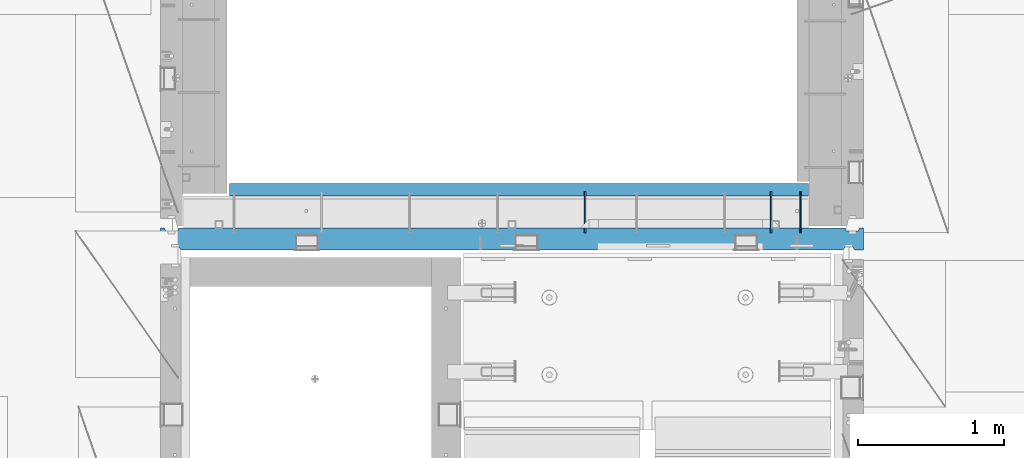
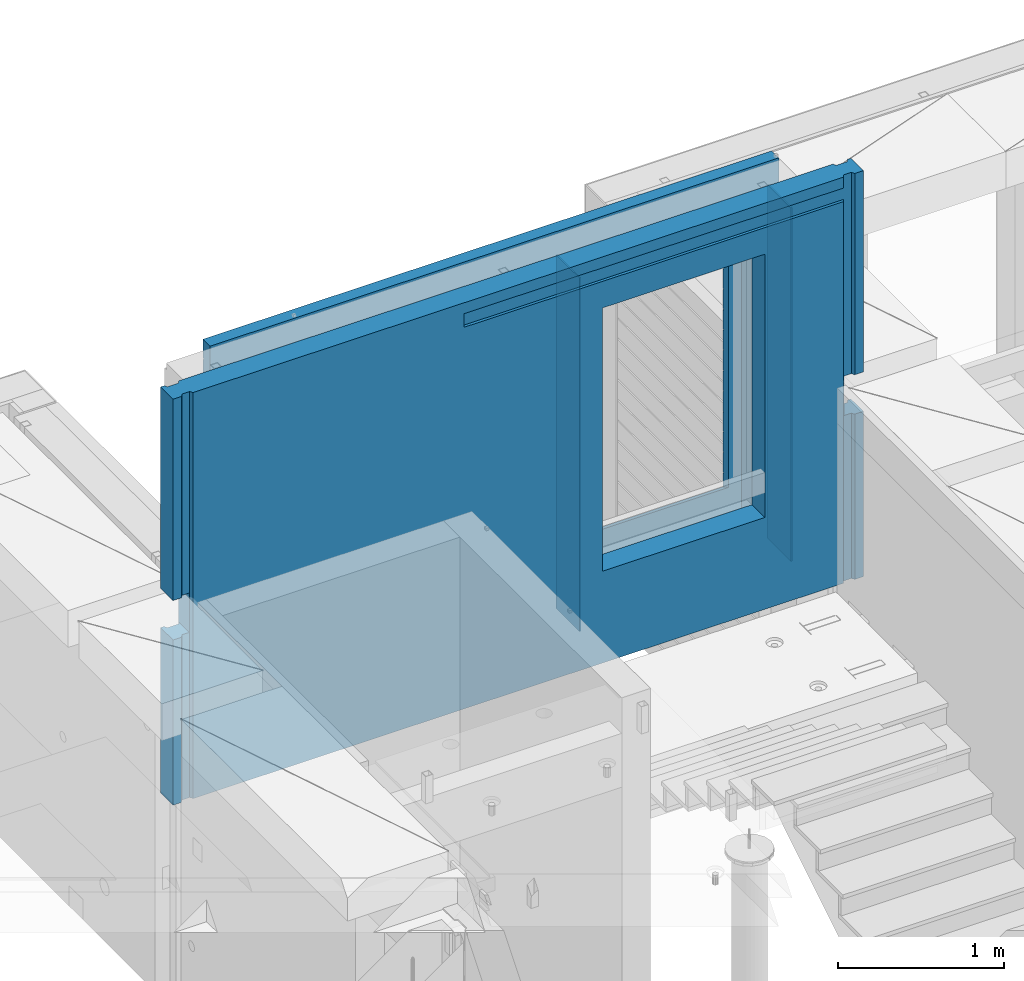
# One storey, part 230 of 341: 5 walls, 1 element without a shape of its own.
"""IFC2X3 building model written with IfcOpenShell, lengths in millimetres."""

import ifcopenshell
import ifcopenshell.guid

model = None  # the IFC model being written
_history = None  # IfcOwnerHistory: only IFC2X3 demands one
_inside = {}  # id of a spatial element -> (the spatial element, [elements in it])
_under = {}  # id of a project, library or spatial element -> (it, [spatial elements below it])
_declared = {}  # id of a project -> (the project, [libraries it declares])
_typed = {}  # id of a type object -> (the type object, [elements of that type])
_made_of = {}  # id of a material, layer set ... -> (it, [elements and type objects made of it])


def new_model(schema):
    """Start an empty IFC model of exactly this schema.

    Asked for "IFC4X3", IfcOpenShell would pick the latest addendum, in which some entities
    have other attributes; the version numbers below select the first issue.
    IFC2X3 requires an IfcOwnerHistory on every rooted entity: one is made here for all.
    """
    global model, _history
    if schema == "IFC4X3":
        model = ifcopenshell.file(schema_version=(4, 3, 0, 0))
    else:
        model = ifcopenshell.file(schema=schema)
    _inside.clear()
    _under.clear()
    _declared.clear()
    _typed.clear()
    _made_of.clear()
    _history = None
    if model.schema == "IFC2X3":
        org = make("IfcOrganization", Name="unknown")
        user = make(
            "IfcPersonAndOrganization",
            ThePerson=make("IfcPerson", FamilyName="unknown"),
            TheOrganization=org,
        )
        app = make(
            "IfcApplication",
            ApplicationDeveloper=org,
            Version="unknown",
            ApplicationFullName="unknown",
            ApplicationIdentifier="unknown",
        )
        _history = make(
            "IfcOwnerHistory",
            OwningUser=user,
            OwningApplication=app,
            ChangeAction="ADDED",
            CreationDate=0,
        )
    return model


def make(cls, **values):
    """One entity of the class cls with the attributes given. An attribute that is None is left unset."""
    return model.create_entity(
        cls, **{name: value for name, value in values.items() if value is not None}
    )


def rooted(cls, **values):
    """An entity with a GlobalId (a new one), such as an element, a storey or a relation."""
    return make(cls, GlobalId=ifcopenshell.guid.new(), OwnerHistory=_history, **values)


def si_unit(unit_type, name, prefix=None):
    """IfcSIUnit, for example si_unit("LENGTHUNIT", "METRE", prefix="MILLI")."""
    return make("IfcSIUnit", UnitType=unit_type, Prefix=prefix, Name=name)


def assignment(units):
    """IfcUnitAssignment: the units of a project."""
    return None if units is None else make("IfcUnitAssignment", Units=units)


def point(xyz):
    """IfcCartesianPoint."""
    return None if xyz is None else make("IfcCartesianPoint", Coordinates=xyz)


def direction(xyz):
    """IfcDirection."""
    return None if xyz is None else make("IfcDirection", DirectionRatios=xyz)


def frame(location, z_axis=None, x_axis=None):
    """IfcAxis2Placement3D, a coordinate frame: its origin and axes. An axis left out is left unset."""
    return make(
        "IfcAxis2Placement3D",
        Location=point(location),
        Axis=direction(z_axis),
        RefDirection=direction(x_axis),
    )


def origin_with_axes():
    """The frame at (0, 0, 0) with the z axis (0, 0, 1) and the x axis (1, 0, 0) written out."""
    return frame((0.0, 0.0, 0.0), z_axis=(0.0, 0.0, 1.0), x_axis=(1.0, 0.0, 0.0))


def place(relative_to, where):
    """IfcLocalPlacement: puts the frame where relative to a parent placement (None: the world)."""
    return make(
        "IfcLocalPlacement", PlacementRelTo=relative_to, RelativePlacement=where
    )


def context(
    kind, dimensions, precision=None, world=None, true_north=None, identifier=None
):
    """IfcGeometricRepresentationContext, for example the 3D "Model" context."""
    return make(
        "IfcGeometricRepresentationContext",
        ContextIdentifier=identifier,
        ContextType=kind,
        CoordinateSpaceDimension=dimensions,
        Precision=precision,
        WorldCoordinateSystem=world,
        TrueNorth=true_north,
    )


def subcontext(parent, identifier, kind, view, scale=None):
    """IfcGeometricRepresentationSubContext, for example "Body" below "Model"."""
    return make(
        "IfcGeometricRepresentationSubContext",
        ContextIdentifier=identifier,
        ContextType=kind,
        ParentContext=parent,
        TargetScale=scale,
        TargetView=view,
    )


def project(units=None, contexts=None):
    """IfcProject with its units and contexts."""
    return rooted(
        "IfcProject",
        Name="project",
        RepresentationContexts=contexts,
        UnitsInContext=assignment(units),
    )


def spatial(cls, under=None, at=None, **own):
    """A site, building, storey or space (cls), placed at a placement, below another one or the project."""
    s = rooted(cls, ObjectPlacement=at, **own)
    if under is not None:
        _under.setdefault(under.id(), (under, []))[1].append(s)
    return s


def faces_of(points, faces, orient=None, outer=None):
    """IfcFace entities. A face is a list of loops; a loop is a list of indices into points, from 0.

    orient and outer hold one flag for each loop. By default every Orientation is true, the
    first loop of a face is its IfcFaceOuterBound and the others are IfcFaceBound.
    """
    made = []
    for i, loops in enumerate(faces):
        bounds = []
        for j, loop in enumerate(loops):
            is_outer = j == 0 if outer is None else outer[i][j]
            bounds.append(
                make(
                    "IfcFaceOuterBound" if is_outer else "IfcFaceBound",
                    Bound=make("IfcPolyLoop", Polygon=[points[k] for k in loop]),
                    Orientation=True if orient is None else orient[i][j],
                )
            )
        made.append(make("IfcFace", Bounds=bounds))
    return made


def faceted_brep(points, faces, orient=None, outer=None, voids=None):
    """IfcFacetedBrep: a solid bounded by flat faces; with voids (closed shells), ...WithVoids."""
    shared = [point(p) for p in points]
    hull = make("IfcClosedShell", CfsFaces=faces_of(shared, faces, orient, outer))
    if voids is None:
        return make("IfcFacetedBrep", Outer=hull)
    return make(
        "IfcFacetedBrepWithVoids",
        Outer=hull,
        Voids=[
            make(cls, CfsFaces=faces_of(shared, fs, o, b)) for cls, fs, o, b in voids
        ],
    )


def shape(context_of_items, identifier, shape_type, items):
    """IfcShapeRepresentation: the items that make up one representation, for example the "Body"."""
    return make(
        "IfcShapeRepresentation",
        ContextOfItems=context_of_items,
        RepresentationIdentifier=identifier,
        RepresentationType=shape_type,
        Items=items,
    )


def material(Name=None, Category=None):
    """IfcMaterial."""
    return make("IfcMaterial", Name=Name, Category=Category)


def made_of(thing, what):
    """Note that an element or type object is made of a material, layer set ...; save() writes the relation."""
    if what is not None:
        _made_of.setdefault(what.id(), (what, []))[1].append(thing)
    return thing


def type_object(cls, material=None, **own):
    """A type object (cls), such as IfcWallType, which elements share."""
    return made_of(rooted(cls, **own), material)


def element(
    cls,
    number,
    at=None,
    inside=None,
    cuts=None,
    type_object=None,
    material=None,
    context=None,
    identifier="Body",
    shape_type=None,
    held_by="IfcProductDefinitionShape",
    body=None,
    shapes=None,
    **own,
):
    """One element of the class cls, such as IfcWall. Its Tag is "e" and its number.

    at: its placement. inside: the storey or other place that contains it. cuts: it is an
    opening in that element (IfcRelVoidsElement). A single representation is given by context,
    identifier, shape_type and body (its items); several are given by shapes. held_by: the class
    of the entity that holds the representations. save() writes the other relations.
    """
    e = rooted(cls, Tag="e%d" % number, ObjectPlacement=at, **own)
    if body is not None:
        shapes = [shape(context, identifier, shape_type, body)]
    if shapes is not None:
        e.Representation = make(held_by, Representations=shapes)
    if inside is not None:
        _inside.setdefault(inside.id(), (inside, []))[1].append(e)
    if cuts is not None:
        rooted(
            "IfcRelVoidsElement", RelatingBuildingElement=cuts, RelatedOpeningElement=e
        )
    if type_object is not None:
        _typed.setdefault(type_object.id(), (type_object, []))[1].append(e)
    return made_of(e, material)


def aggregate(whole, parts):
    """IfcRelAggregates: a whole, such as a stair, and the parts it consists of."""
    return rooted("IfcRelAggregates", RelatingObject=whole, RelatedObjects=parts)


def save(model, path):
    """Write the relations noted so far, then the file.

    IfcRelAggregates (storeys below a building ...), IfcRelContainedInSpatialStructure (elements
    in a storey), IfcRelDefinesByType, IfcRelAssociatesMaterial and IfcRelDeclares: one each for
    every whole, place, type object, material and project.
    """
    for whole, parts in _under.values():
        aggregate(whole, parts)
    for where, things in _inside.values():
        rooted(
            "IfcRelContainedInSpatialStructure",
            RelatedElements=things,
            RelatingStructure=where,
        )
    for kind, things in _typed.values():
        rooted("IfcRelDefinesByType", RelatedObjects=things, RelatingType=kind)
    for what, things in _made_of.values():
        rooted("IfcRelAssociatesMaterial", RelatedObjects=things, RelatingMaterial=what)
    for by, libraries in _declared.values():
        rooted("IfcRelDeclares", RelatingContext=by, RelatedDefinitions=libraries)
    model.write(path)


model = new_model("IFC2X3")

# Units and contexts
model_context = context("Model", 3, precision=1e-05, world=origin_with_axes())
body_context = subcontext(model_context, "Body", "Model", "MODEL_VIEW")
ifc_project = project(units=[si_unit("LENGTHUNIT", "METRE", prefix="MILLI"), si_unit("AREAUNIT", "SQUARE_METRE"), si_unit("VOLUMEUNIT", "CUBIC_METRE"), si_unit("MASSUNIT", "GRAM", prefix="KILO"), si_unit("TIMEUNIT", "SECOND"), si_unit("PLANEANGLEUNIT", "RADIAN"), si_unit("SOLIDANGLEUNIT", "STERADIAN"), si_unit("THERMODYNAMICTEMPERATUREUNIT", "DEGREE_CELSIUS"), si_unit("LUMINOUSINTENSITYUNIT", "LUMEN")], contexts=[model_context])

# Site, building, storey
site_placement = place(None, origin_with_axes())
site = spatial("IfcSite", under=ifc_project, at=site_placement, CompositionType="ELEMENT")
building_placement = place(site_placement, origin_with_axes())
building = spatial("IfcBuilding", under=site, at=building_placement, CompositionType="ELEMENT")
storey_placement = place(building_placement, origin_with_axes())
storey = spatial("IfcBuildingStorey", under=building, at=storey_placement, Name="5", CompositionType="ELEMENT", Elevation=0.0)

# Assembly, walls
assembly_placement = place(storey_placement, origin_with_axes())
assembly = element("IfcElementAssembly", 1, at=assembly_placement, inside=storey, AssemblyPlace="NOTDEFINED", PredefinedType="REINFORCEMENT_UNIT")
ifc_material_1 = material(Name="Undefined")
wall_type_1 = type_object("IfcWallType", PredefinedType="NOTDEFINED")
wall_1_placement = place(assembly_placement, frame((21980.0002441406, 20550.0, 96745.0), z_axis=(0.0, 0.0, 1.0), x_axis=(0.0, 1.0, 0.0)))
wall_1 = element("IfcWall", 2, at=wall_1_placement, type_object=wall_type_1, material=ifc_material_1, Name="(PD)", context=body_context, shape_type="Brep", body=[
    faceted_brep([(0.0, 5.0, -1300.0), (0.0, 5.0, 1300.0), (280.0, 5.0, 1300.0), (280.0, 5.0, -1300.0), (0.0, -5.0, 1300.0), (280.0, -5.0, 1300.0), (0.0, -5.0, -1300.0), (280.0, -5.0, -1300.0)], [[[0, 1, 2, 3]], [[1, 4, 5, 2]], [[4, 6, 7, 5]], [[6, 0, 3, 7]], [[5, 7, 3, 2]], [[6, 4, 1, 0]]]),
])
wall_2_placement = place(assembly_placement, frame((20510.0002441406, 20550.0, 96745.0), z_axis=(0.0, 0.0, 1.0), x_axis=(0.0, 1.0, 0.0)))
wall_2 = element("IfcWall", 3, at=wall_2_placement, type_object=wall_type_1, material=ifc_material_1, Name="(PD)", context=body_context, shape_type="Brep", body=[
    faceted_brep([(0.0, 5.0, -1300.0), (0.0, 5.0, 1300.0), (280.0, 5.0, 1300.0), (280.0, 5.0, -1300.0), (0.0, -5.0, 1300.0), (280.0, -5.0, 1300.0), (0.0, -5.0, -1300.0), (280.0, -5.0, -1300.0)], [[[0, 1, 2, 3]], [[1, 4, 5, 2]], [[4, 6, 7, 5]], [[6, 0, 3, 7]], [[5, 7, 3, 2]], [[6, 4, 1, 0]]]),
])
wall_3_placement = place(assembly_placement, frame((21780.0002441406, 20550.0, 96745.0), z_axis=(0.0, 0.0, 1.0), x_axis=(0.0, 1.0, 0.0)))
wall_3 = element("IfcWall", 4, at=wall_3_placement, type_object=wall_type_1, material=ifc_material_1, Name="(PD)", context=body_context, shape_type="Brep", body=[
    faceted_brep([(0.0, 5.0, -1300.0), (0.0, 5.0, 1300.0), (280.0, 5.0, 1300.0), (280.0, 5.0, -1300.0), (0.0, -5.0, 1300.0), (280.0, -5.0, 1300.0), (0.0, -5.0, -1300.0), (280.0, -5.0, -1300.0)], [[[0, 1, 2, 3]], [[1, 4, 5, 2]], [[4, 6, 7, 5]], [[6, 0, 3, 7]], [[5, 7, 3, 2]], [[6, 4, 1, 0]]]),
])
ifc_material_2 = material(Name="CONCRETE/C30/37")
wall_type_2 = type_object("IfcWallType", PredefinedType="NOTDEFINED")
wall_4_placement = place(assembly_placement, frame((18080.0, 20842.5, 96747.5), z_axis=(0.0, 0.0, 1.0), x_axis=(1.0, 0.0, 0.0)))
wall_4 = element("IfcWall", 5, at=wall_4_placement, type_object=wall_type_2, material=ifc_material_2, context=body_context, shape_type="Brep", body=[
    faceted_brep([(3955.0, 32.4999992499397, 1344.99999999921), (-3.63797880709171e-12, 32.4999992507037, 1344.99999999926), (-3.63797880709171e-12, 32.4999991127006, 1355.00000040044), (3955.0, 32.4999991119439, 1355.00000040044), (3955.0, 42.4999996032966, 1342.99999994476), (0.0, 42.5, 1342.99999994476), (3955.0, 42.4999992424127, 1206.99999988926), (0.0, 42.5, 1206.99999988925), (3955.0, 32.4999991119475, 1205.00000040044), (0.0, 32.4999991127006, 1205.00000040044), (3955.0, 32.4999992499506, 1194.99999999921), (0.0, 32.4999992507037, 1194.99999999926), (3955.0, 42.4999994790196, 1192.99999994478), (0.0, 42.5, 1192.99999994476), (3955.0, 32.499999111973, 1055.00000040044), (3955.0, 32.4999992499688, 1044.99999999921), (3613.82193430323, 32.4999992499688, 1044.99999999921), (3613.821934287, 32.499999111973, 1055.00000040044), (3955.0, 42.4999994184, 1042.99999994476), (3614.99840497971, 42.4999994684003, 1042.99999994476), (3955.0, 42.4999992424309, 906.999999889245), (3614.99840497971, 42.499999307558, 906.999999889245), (3955.0, 32.4999991119621, 905.000000400425), (3613.821934287, 32.4999991119621, 905.000000400425), (3955.0, 32.4999992499652, 894.9999999992), (3613.82193430323, 32.4999992499652, 894.9999999992), (3955.0, 42.4999993825222, 892.999999944761), (3614.99840497971, 42.499999435604, 892.999999944761), (3955.0, 42.4999992424418, 756.999999889231), (3614.99840497971, 42.4999993075689, 756.999999889231), (3955.0, 32.4999991119766, 755.000000400411), (3613.821934287, 32.4999991119766, 755.000000400411), (3955.0, 32.4999992499797, 744.999999999185), (3613.82193430324, 32.4999992499797, 744.999999999185), (3955.0, 42.4999993588208, 742.999999944746), (3614.99840497971, 42.4999994139398, 742.999999944746), (3955.0, 42.4999992424746, 606.999999889231), (3614.99840497971, 42.499999307598, 606.999999889231), (3955.0, 32.4999991120058, 605.000000400425), (3613.821934287, 32.4999991120058, 605.000000400425), (3955.0, 32.4999992499979, 594.9999999992), (3613.82193430324, 32.4999992499979, 594.9999999992), (3955.0, 42.4999993419697, 592.999999944746), (3614.99840497971, 42.4999993985402, 592.999999944746), (3955.0, 42.4999992424782, 456.99999988926), (3614.99840497971, 42.4999993076017, 456.99999988926), (3955.0, 32.499999112013, 455.00000040044), (3613.821934287, 32.499999112013, 455.00000040044), (3955.0, 32.4999992500161, 444.999999999214), (3613.82193430324, 32.4999992500161, 444.999999999214), (3955.0, 42.4999993293859, 442.999999944775), (3614.99840497971, 42.499999387037, 442.999999944775), (3955.0, 42.4999992424855, 306.999999889245), (3614.99840497971, 42.499999307609, 306.999999889245), (3955.0, 32.4999991120167, 305.000000400425), (3613.82193428701, 32.4999991120167, 305.000000400425), (3955.0, 32.4999992500234, 294.9999999992), (3613.82193430324, 32.4999992500234, 294.9999999992), (3955.0, 42.4999993196434, 292.999999944761), (3614.99840497971, 42.4999993781312, 292.999999944761), (3955.0, 42.4999992425037, 156.999999889245), (3614.99840497971, 42.4999993076235, 156.999999889245), (3955.0, 32.4999991120349, 155.000000400425), (3613.82193428701, 32.4999991120349, 155.000000400425), (3955.0, 32.4999992500379, 144.9999999992), (3613.82193430324, 32.4999992500379, 144.9999999992), (3955.0, 42.4999993118727, 142.999999944761), (3614.99840497971, 42.4999993710298, 142.999999944761), (3955.0, 42.4999992425255, 6.99999988924537), (3614.99840497971, 42.4999993076453, 6.99999988924537), (3955.0, 32.4999991120567, 5.0000004004396), (3613.82193428701, 32.4999991120567, 5.0000004004396), (3955.0, 32.4999992500489, -5.0000000007858), (3613.82193430325, 32.4999992500489, -5.0000000007858), (3955.0, 42.4999993095153, -7.00000005523907), (3614.99840497971, 42.4999993688762, -7.00000005523907), (3955.0, 42.4999992468911, -143.000000110784), (3614.99840497971, 42.4999993116326, -143.000000110784), (3955.0, 32.4999991164223, -144.999999599604), (3613.82193428752, 32.4999991164223, -144.999999599604), (3955.0, 32.4999992544181, -155.000000000829), (3613.82193430376, 32.4999992544181, -155.000000000829), (3955.0, 42.4999993037636, -157.000000055268), (3614.99840497971, 42.4999993636156, -157.000000055268), (3955.0, 42.4999992463599, -293.000000110755), (3614.99840497971, 42.4999993111487, -293.000000110755), (3955.0, 32.4999991158911, -294.999999599575), (3613.82193428746, 32.4999991158911, -294.999999599575), (3955.0, 32.4999992538869, -305.000000000786), (3613.82193430369, 32.4999992538869, -305.000000000786), (3955.0, 42.4999992988232, -307.000000055239), (3614.99840497971, 42.4999993591009, -307.000000055239), (3955.0, 42.4999992458288, -443.000000110755), (3614.99840497971, 42.4999993106612, -443.000000110755), (3955.0, 32.49999911536, -444.999999599575), (3613.8219342874, 32.49999911536, -444.999999599575), (3955.0, 32.4999992533558, -455.0000000008), (3613.82193430363, 32.4999992533558, -455.0000000008), (3955.0, 42.4999992945195, -457.000000055239), (3614.99840497971, 42.4999993551683, -457.000000055239), (3955.0, 42.4999992453049, -593.00000011074), (3614.99840497971, 42.4999993101846, -593.00000011074), (3955.0, 32.4999991148361, -594.99999959956), (3613.82193428733, 32.4999991148361, -594.99999959956), (3955.0, 32.4999992528319, -605.000000000786), (3613.82193430357, 32.4999992528319, -605.000000000786), (3955.0, 42.4999992907105, -607.000000055225), (3614.99840497971, 42.4999993516867, -607.000000055225), (3955.0, 42.4999992447629, -743.000000110755), (3614.99840497971, 42.4999993096899, -743.000000110755), (3955.0, 32.499999114294, -744.999999599575), (3613.82193428727, 32.499999114294, -744.999999599575), (3955.0, 32.4999992522935, -755.0000000008), (3613.82193430351, 32.4999992522935, -755.0000000008), (3955.0, 42.4999992873236, -757.000000055239), (3614.99840497971, 42.4999993485908, -757.000000055239), (0.0, -42.5, -1492.5), (0.0, 42.5, -1492.5), (3955.0, 42.5, -1492.5), (3955.0, -42.5, -1492.5), (0.0, 42.5, -1357.00000005524), (3955.0, 42.5, -1357.00000005524), (0.0, 32.4999992507037, -1355.00000000074), (3955.0, 32.4999992501653, -1355.00000000079), (0.0, 32.4999991127006, -1344.99999959956), (3955.0, 32.4999991121695, -1344.99999959956), (3955.0, 42.4999992426383, -1343.00000011075), (0.0, 42.5, -1343.00000011075), (0.0, 42.5, -1207.00000005524), (3955.0, 42.4999992789635, -1207.00000005522), (0.0, 32.4999992507037, -1205.00000000074), (3955.0, 32.4999992506928, -1205.00000000079), (0.0, 32.4999991127006, -1194.99999959956), (3955.0, 32.499999112697, -1194.99999959956), (3955.0, 42.4999992431658, -1193.00000011074), (0.0, 42.5, -1193.00000011075), (0.0, 42.5, -1057.00000005524), (3955.0, 42.4999992814919, -1057.00000005525), (0.0, 32.4999992507037, -1055.00000000074), (3955.0, 32.4999992512312, -1055.00000000081), (0.0, 32.4999991127006, -1044.99999959956), (3955.0, 32.4999991132318, -1044.99999959959), (3955.0, 42.4999992437006, -1043.00000011077), (0.0, 42.5, -1043.00000011075), (0.0, 42.5, -907.000000055239), (3955.0, 42.4999992842677, -907.000000055225), (0.0, 32.4999992507037, -905.000000000742), (3955.0, 32.499999251766, -905.000000000771), (0.0, 32.4999991127006, -894.99999959956), (3955.0, 32.4999991137665, -894.99999959956), (3955.0, 42.4999992442354, -893.00000011074), (0.0, 42.5, -893.000000110755), (0.0, 32.4999991127006, 1055.00000040044), (0.0, 42.5, 1056.99999988925), (2544.99840497971, 42.4999995125218, 1056.99999988925), (2546.17487567242, 32.499999111973, 1055.00000040044), (0.0, 32.4999992507037, 1044.99999999926), (2546.17487565618, 32.4999992499688, 1044.99999999921), (0.0, 42.5, 1042.99999994476), (2544.99840497971, 42.4999996257466, 1042.99999994476), (0.0, 42.5, 906.999999889245), (2544.99840497971, 42.4999995125145, 906.999999889245), (0.0, 32.4999991127006, 905.00000040044), (2546.17487567242, 32.4999991119621, 905.000000400425), (0.0, 32.4999992507037, 894.999999999258), (2546.17487565618, 32.4999992499652, 894.9999999992), (0.0, 42.5, 892.999999944761), (2544.99840497971, 42.49999960266, 892.999999944761), (0.0, 42.5, 756.999999889245), (2544.99840497971, 42.4999995125218, 756.999999889231), (0.0, 32.4999991127006, 755.00000040044), (2546.17487567242, 32.4999991119766, 755.000000400411), (0.0, 32.4999992507037, 744.999999999258), (2546.17487565618, 32.4999992499797, 744.999999999185), (0.0, 42.5, 742.999999944761), (2544.99840497971, 42.4999995874059, 742.999999944746), (0.0, 42.5, 606.999999889245), (2544.99840497971, 42.4999995125399, 606.999999889231), (3.63797880709171e-12, 32.4999991127006, 605.00000040044), (2546.17487567241, 32.4999991120058, 605.000000400425), (3.63797880709171e-12, 32.4999992507037, 594.999999999258), (2546.17487565618, 32.4999992499979, 594.9999999992), (0.0, 42.5, 592.999999944761), (2544.99840497971, 42.4999995765647, 592.999999944746), (0.0, 42.5, 456.999999889245), (2544.99840497971, 42.4999995125436, 456.99999988926), (0.0, 32.4999991127006, 455.00000040044), (2546.17487567241, 32.499999112013, 455.00000040044), (0.0, 32.4999992507037, 444.999999999258), (2546.17487565617, 32.4999992500161, 444.999999999214), (0.0, 42.5, 442.999999944761), (2544.99840497971, 42.4999995684666, 442.999999944775), (0.0, 42.5, 306.999999889245), (2544.99840497971, 42.4999995125509, 306.999999889245), (-3.63797880709171e-12, 32.4999991127006, 305.00000040044), (2546.17487567241, 32.4999991120167, 305.000000400425), (-3.63797880709171e-12, 32.4999992507037, 294.999999999258), (2546.17487565617, 32.4999992500234, 294.9999999992), (0.0, 42.5, 292.999999944761), (2544.99840497971, 42.4999995621984, 292.999999944761), (0.0, 42.5, 156.999999889245), (2544.99840497971, 42.4999995125581, 156.999999889245), (-3.63797880709171e-12, 32.4999991127006, 155.00000040044), (2546.17487567241, 32.4999991120349, 155.000000400425), (-3.63797880709171e-12, 32.4999992507037, 144.999999999258), (2546.17487565617, 32.4999992500379, 144.9999999992), (0.0, 42.5, 142.999999944761), (2544.99840497971, 42.4999995571998, 142.999999944761), (0.0, 42.5, 6.99999988924537), (2544.99840497971, 42.4999995125763, 6.99999988924537), (0.0, 32.4999991127006, 5.0000004004396), (2546.1748756724, 32.4999991120567, 5.0000004004396), (0.0, 32.4999992507037, -5.00000000074215), (2546.17487565617, 32.4999992500489, -5.0000000007858), (0.0, 42.5, -7.00000005523907), (2544.99840497971, 42.4999995556827, -7.00000005523907), (0.0, 42.5, -143.000000110755), (2544.99840497971, 42.4999995153812, -143.000000110784), (3.63797880709171e-12, 32.4999991127006, -144.99999959956), (2546.17487567189, 32.4999991164223, -144.999999599604), (3.63797880709171e-12, 32.4999992507037, -155.000000000742), (2546.17487565566, 32.4999992544181, -155.000000000829), (0.0, 42.5, -157.000000055239), (2544.99840497971, 42.4999995519793, -157.000000055268), (0.0, 42.5, -293.000000110755), (2544.99840497971, 42.4999995150429, -293.000000110755), (0.0, 32.4999991127006, -294.99999959956), (2546.17487567195, 32.4999991158911, -294.999999599575), (0.0, 32.4999992507037, -305.000000000742), (2546.17487565572, 32.4999992538869, -305.000000000786), (0.0, 42.5, -307.000000055239), (2544.99840497971, 42.4999995487997, -307.000000055239), (0.0, 42.5, -443.000000110755), (2544.99840497971, 42.4999995146973, -443.000000110755), (0.0, 32.4999991127006, -444.99999959956), (2546.17487567201, 32.49999911536, -444.999999599575), (0.0, 32.4999992507037, -455.000000000742), (2546.17487565578, 32.4999992533558, -455.0000000008), (0.0, 42.5, -457.000000055239), (2544.99840497971, 42.4999995460312, -457.000000055239), (0.0, 42.5, -593.000000110755), (2544.99840497971, 42.4999995143626, -593.00000011074), (3.63797880709171e-12, 32.4999991127006, -594.99999959956), (2546.17487567208, 32.4999991148361, -594.99999959956), (3.63797880709171e-12, 32.4999992507037, -605.000000000742), (2546.17487565584, 32.4999992528319, -605.000000000786), (0.0, 42.5, -607.000000055239), (2544.99840497971, 42.4999995435792, -607.000000055225), (0.0, 42.5, -743.000000110755), (2544.99840497971, 42.4999995140133, -743.000000110755), (0.0, 32.4999991127006, -744.99999959956), (2546.17487567214, 32.499999114294, -744.999999599575), (0.0, 32.4999992507037, -755.000000000742), (2546.17487565591, 32.4999992522935, -755.0000000008), (0.0, 42.5, -757.000000055239), (2544.99840497971, 42.4999995414, -757.000000055239), (2544.99840497971, 42.5, -857.5), (3614.99840497971, 42.5, -857.5), (2554.99840497971, -42.5, -807.5), (3604.99840497971, -42.5, -807.5), (0.0, -42.5, 1492.5), (3955.0, -42.5, 1492.5), (2554.99840497971, -42.5, 1082.5), (2554.99840497971, -42.5, 1087.5), (3604.99840497971, -42.5, 1087.5), (3604.99840497971, -42.5, 1082.5), (0.0, 42.5, 1492.5), (3955.0, 42.5, 1492.5), (3955.0, 42.4999992424164, 1356.99999988925), (0.0, 42.5, 1356.99999988925), (3955.0, 42.4999992424455, 1056.99999988925), (2554.99840497971, 42.5, 1082.5), (2544.99840497971, 42.5, 1082.5), (3614.99840497971, 42.4999993075689, 1056.99999988925), (3614.99840497971, 42.5, 1082.5), (3604.99840497971, 42.5, 1082.5)], [[[0, 1, 2, 3]], [[4, 5, 1, 0]], [[6, 7, 5, 4]], [[6, 8, 9, 7]], [[10, 11, 9, 8]], [[12, 13, 11, 10]], [[14, 15, 16, 17]], [[15, 18, 19, 16]], [[18, 20, 21, 19]], [[20, 22, 23, 21]], [[22, 24, 25, 23]], [[24, 26, 27, 25]], [[26, 28, 29, 27]], [[28, 30, 31, 29]], [[30, 32, 33, 31]], [[32, 34, 35, 33]], [[34, 36, 37, 35]], [[36, 38, 39, 37]], [[38, 40, 41, 39]], [[40, 42, 43, 41]], [[42, 44, 45, 43]], [[44, 46, 47, 45]], [[46, 48, 49, 47]], [[48, 50, 51, 49]], [[50, 52, 53, 51]], [[52, 54, 55, 53]], [[54, 56, 57, 55]], [[56, 58, 59, 57]], [[58, 60, 61, 59]], [[60, 62, 63, 61]], [[62, 64, 65, 63]], [[64, 66, 67, 65]], [[66, 68, 69, 67]], [[68, 70, 71, 69]], [[70, 72, 73, 71]], [[72, 74, 75, 73]], [[74, 76, 77, 75]], [[76, 78, 79, 77]], [[78, 80, 81, 79]], [[80, 82, 83, 81]], [[82, 84, 85, 83]], [[84, 86, 87, 85]], [[86, 88, 89, 87]], [[88, 90, 91, 89]], [[90, 92, 93, 91]], [[92, 94, 95, 93]], [[94, 96, 97, 95]], [[96, 98, 99, 97]], [[98, 100, 101, 99]], [[100, 102, 103, 101]], [[102, 104, 105, 103]], [[104, 106, 107, 105]], [[106, 108, 109, 107]], [[108, 110, 111, 109]], [[110, 112, 113, 111]], [[112, 114, 115, 113]], [[116, 117, 118, 119]], [[118, 117, 120, 121]], [[121, 120, 122, 123]], [[123, 122, 124, 125]], [[126, 125, 124, 127]], [[126, 127, 128, 129]], [[129, 128, 130, 131]], [[131, 130, 132, 133]], [[134, 133, 132, 135]], [[134, 135, 136, 137]], [[137, 136, 138, 139]], [[139, 138, 140, 141]], [[142, 141, 140, 143]], [[142, 143, 144, 145]], [[145, 144, 146, 147]], [[147, 146, 148, 149]], [[150, 149, 148, 151]], [[152, 153, 154, 155]], [[156, 152, 155, 157]], [[158, 156, 157, 159]], [[160, 158, 159, 161]], [[162, 160, 161, 163]], [[164, 162, 163, 165]], [[166, 164, 165, 167]], [[168, 166, 167, 169]], [[170, 168, 169, 171]], [[172, 170, 171, 173]], [[174, 172, 173, 175]], [[176, 174, 175, 177]], [[178, 176, 177, 179]], [[180, 178, 179, 181]], [[182, 180, 181, 183]], [[184, 182, 183, 185]], [[186, 184, 185, 187]], [[188, 186, 187, 189]], [[190, 188, 189, 191]], [[192, 190, 191, 193]], [[194, 192, 193, 195]], [[196, 194, 195, 197]], [[198, 196, 197, 199]], [[200, 198, 199, 201]], [[202, 200, 201, 203]], [[204, 202, 203, 205]], [[206, 204, 205, 207]], [[208, 206, 207, 209]], [[210, 208, 209, 211]], [[212, 210, 211, 213]], [[214, 212, 213, 215]], [[216, 214, 215, 217]], [[218, 216, 217, 219]], [[220, 218, 219, 221]], [[222, 220, 221, 223]], [[224, 222, 223, 225]], [[226, 224, 225, 227]], [[228, 226, 227, 229]], [[230, 228, 229, 231]], [[232, 230, 231, 233]], [[234, 232, 233, 235]], [[236, 234, 235, 237]], [[238, 236, 237, 239]], [[240, 238, 239, 241]], [[242, 240, 241, 243]], [[244, 242, 243, 245]], [[246, 244, 245, 247]], [[248, 246, 247, 249]], [[250, 248, 249, 251]], [[252, 250, 251, 253]], [[254, 252, 253, 255]], [[114, 150, 151, 254, 255, 256, 257, 115]], [[256, 258, 259, 257]], [[260, 116, 119, 261], [259, 258, 262, 263, 264, 265]], [[266, 260, 261, 267]], [[266, 267, 268, 269]], [[1, 5, 7, 9, 11, 13, 153, 152, 156, 158, 160, 162, 164, 166, 168, 170, 172, 174, 176, 178, 180, 182, 184, 186, 188, 190, 192, 194, 196, 198, 200, 202, 204, 206, 208, 210, 212, 214, 216, 218, 220, 222, 224, 226, 228, 230, 232, 234, 236, 238, 240, 242, 244, 246, 248, 250, 252, 254, 151, 148, 146, 144, 143, 140, 138, 136, 135, 132, 130, 128, 127, 124, 122, 120, 117, 116, 260, 266, 269, 2]], [[268, 3, 2, 269]], [[267, 261, 119, 118, 121, 123, 125, 126, 129, 131, 133, 134, 137, 139, 141, 142, 145, 147, 149, 150, 114, 112, 110, 108, 106, 104, 102, 100, 98, 96, 94, 92, 90, 88, 86, 84, 82, 80, 78, 76, 74, 72, 70, 68, 66, 64, 62, 60, 58, 56, 54, 52, 50, 48, 46, 44, 42, 40, 38, 36, 34, 32, 30, 28, 26, 24, 22, 20, 18, 15, 14, 270, 12, 10, 8, 6, 4, 0, 3, 268]], [[271, 272, 154, 153, 13, 12, 270, 273, 274, 275]], [[262, 258, 256, 255, 253, 251, 249, 247, 245, 243, 241, 239, 237, 235, 233, 231, 229, 227, 225, 223, 221, 219, 217, 215, 213, 211, 209, 207, 205, 203, 201, 199, 197, 195, 193, 191, 189, 187, 185, 183, 181, 179, 177, 175, 173, 171, 169, 167, 165, 163, 161, 159, 157, 155, 154, 272, 263]], [[271, 275, 274, 264, 263, 272]], [[273, 17, 16, 19, 21, 23, 25, 27, 29, 31, 33, 35, 37, 39, 41, 43, 45, 47, 49, 51, 53, 55, 57, 59, 61, 63, 65, 67, 69, 71, 73, 75, 77, 79, 81, 83, 85, 87, 89, 91, 93, 95, 97, 99, 101, 103, 105, 107, 109, 111, 113, 115, 257, 259, 265, 264, 274]], [[270, 14, 17, 273]]]),
])
ifc_material_3 = material(Name="CONCRETE/C25/30")
wall_type_3 = type_object("IfcWallType", PredefinedType="NOTDEFINED")
wall_5_placement = place(assembly_placement, frame((17610.0, 20505.0, 96747.5), z_axis=(0.0, 0.0, 1.0), x_axis=(1.0, 0.0, 0.0)))
wall_5 = element("IfcWall", 6, at=wall_5_placement, type_object=wall_type_3, material=ifc_material_3, context=body_context, shape_type="Brep", body=[
    faceted_brep([(115.000000752763, 54.9999994575555, -277.499999999956), (35.0000012841592, 54.9999974671882, -277.499999999956), (25.0000034119694, 75.0, -277.499999999956), (0.0, 75.0, -277.499999999956), (0.0, -75.0, -277.499999999956), (59.9999958419066, -75.0, -277.499999999956), (73.0000021298038, -54.9999990274482, -277.499999999956), (125.000000000065, -54.9999987501142, -277.499999999956), (124.999999335741, 75.0, -277.499999999956), (125.000000000065, 74.9999996833285, 12.5000000000582), (125.000000000065, -54.9999987501142, 12.5000000000582), (73.0000021298038, -54.9999990274482, 12.5000000000437), (59.9999958419066, -75.0, 12.5000000000437), (0.0, -75.0, 12.5000000000437), (0.0, 75.0, 12.5000000000437), (25.0000034119694, 75.0, 12.5000000000437), (35.0000012841592, 54.9999974671882, 12.5000000000437), (115.000000752763, 54.9999994575555, 12.5000000000582), (4684.99999994252, 55.0000001373264, 1492.5), (4765.0000011171, 55.0000001731059, 1492.5), (4765.0000011171, 55.0000001731059, 12.5000000000582), (4684.99999994252, 55.0000001373264, 12.5000000000437), (2023.0, -55.0, 1412.5), (2023.0, -55.0, 1312.5), (4673.0, -55.0, 1312.5), (4673.0, -55.0, 1412.5), (4659.9999958419, -75.0, 1492.5), (4659.9999958419, -75.0, 1412.5), (4672.99999996855, -54.9999999109459, 1492.5), (2023.0, -75.0, 1412.5), (2023.0, -75.0, 1312.5), (4659.9999958419, -75.0, 1312.5), (4659.9999958419, -75.0, -1492.5), (4672.99999996855, -54.9999999109459, -1492.5), (4726.9999998731, -54.9999987450756, -1492.5), (4740.00000278436, -75.0, -1492.5), (4740.00000278436, -75.0000009276337, -277.499999999956), (4726.9999998731, -54.9999987450756, -277.499999999956), (4684.99999994252, 55.0000001373264, -1492.5), (4675.0, 75.0, -1492.5), (4675.0, 75.0, -277.499999999956), (4684.99999994252, 55.0000001373264, -277.499999999956), (4765.0000011171, 55.0000001731059, -1492.5), (4765.0000011171, 55.0000001731059, -277.499999999956), (4774.99999933574, 75.0, -1492.5), (4774.99999933574, 75.0000000182044, -277.499999999956), (4800.0, 75.0, -1492.5), (4800.0, 75.0, -277.499999999956), (4800.0, -75.0, -1492.5), (4800.0, -75.0, -277.499999999956), (4674.9999998891, -54.9999999110878, -277.499999999956), (4675.0, 75.0, 12.5000000000437), (4675.00000000007, -54.9999999110878, 12.5000000000437), (4726.9999998731, -54.9999987450756, 1492.5), (4726.9999998731, -54.9999987450756, 12.5000000000582), (4740.00000278436, -75.0000022790009, 1492.5), (4740.00000278436, -75.0000011490447, 12.5000000000582), (4800.0, -75.0, 1492.5), (4800.0, -75.0, 12.5000000000582), (4800.0, 75.0, 1492.5), (4800.00000000007, 74.9999996833285, 12.5000000000582), (4774.99999933574, 75.0000000447253, 1492.5), (4774.99999933574, 75.0000000225482, 12.5000000000582), (4675.0, 75.0, 1492.5), (35.0000012841592, 54.9999974671882, 1492.5), (25.0000034119694, 75.0, 1492.5), (0.0, 75.0, 1492.5), (0.0, -75.0, 1492.5), (59.9999958419066, -75.0, 1492.5), (73.0000021298038, -54.9999990274482, 1492.5), (126.999999875414, -54.9999987394476, 1492.5), (140.000002784363, -75.0, 1492.5), (124.999999335741, 75.0, 1492.5), (115.000000752763, 54.9999994575555, 1492.5), (73.0000021298038, -54.9999990274482, -1492.5), (126.999999875414, -54.9999987394476, -1492.5), (59.9999958419066, -75.0, -1492.5), (0.0, -75.0, -1492.5), (0.0, 75.0, -1492.5), (25.0000034119694, 75.0, -1492.5), (35.0000012841592, 54.9999974671882, -1492.5), (115.000000752763, 54.9999994575555, -1492.5), (124.999999335741, 75.0, -1492.5), (140.000002784363, -75.0, -1492.5), (2984.99840497971, -75.0000022790045, -817.5), (2984.99840497971, -75.0000022790045, 1117.5), (4114.99840497971, -75.0000022790045, 1117.5), (4114.99840497971, -75.0000022790045, -817.5), (2989.05245909535, 75.0, 1113.44594588435), (2989.05245909535, 75.0, -813.445945884348), (4110.94435086406, 75.0, -813.445945884348), (4110.94435086406, 75.0, 1113.44594588435)], [[[0, 1, 2, 3, 4, 5, 6, 7, 8]], [[9, 10, 11, 12, 13, 14, 15, 16, 17]], [[8, 7, 10, 9]], [[18, 19, 20, 21]], [[22, 23, 24, 25]], [[26, 27, 25, 28]], [[29, 22, 25, 27]], [[30, 23, 22, 29]], [[23, 30, 31, 24]], [[31, 32, 33, 24]], [[34, 35, 36, 37]], [[38, 39, 40, 41]], [[42, 38, 41, 43]], [[44, 42, 43, 45]], [[46, 44, 45, 47]], [[48, 46, 47, 49]], [[35, 48, 49, 36]], [[47, 45, 43, 41, 40, 50, 37, 36, 49]], [[51, 52, 50, 40]], [[53, 28, 25, 24, 33, 34, 37, 50, 52, 54]], [[55, 53, 54, 56]], [[57, 55, 56, 58]], [[59, 57, 58, 60]], [[61, 59, 60, 62]], [[19, 61, 62, 20]], [[60, 58, 56, 54, 52, 51, 21, 20, 62]], [[63, 18, 21, 51]], [[64, 65, 66, 67, 68, 69, 70, 71, 26, 28, 53, 55, 57, 59, 61, 19, 18, 63, 72, 73]], [[73, 72, 9, 17]], [[64, 73, 17, 16]], [[65, 64, 16, 15]], [[66, 65, 15, 14]], [[67, 66, 14, 13]], [[68, 67, 13, 12]], [[69, 68, 12, 11]], [[6, 74, 75, 70, 69, 11, 10, 7]], [[76, 74, 6, 5]], [[77, 76, 5, 4]], [[78, 77, 4, 3]], [[79, 78, 3, 2]], [[80, 79, 2, 1]], [[81, 80, 1, 0]], [[82, 81, 0, 8]], [[39, 38, 42, 44, 46, 48, 35, 34, 33, 32, 83, 75, 74, 76, 77, 78, 79, 80, 81, 82]], [[71, 70, 75, 83]], [[32, 31, 30, 29, 27, 26, 71, 83], [84, 85, 86, 87]], [[88, 85, 84, 89]], [[87, 90, 89, 84]], [[86, 91, 90, 87]], [[85, 88, 91, 86]], [[72, 63, 51, 40, 39, 82, 8, 9], [89, 90, 91, 88]]]),
])
aggregate(assembly, [wall_4, wall_1, wall_2, wall_3, wall_5])

save(model, "model.ifc")
